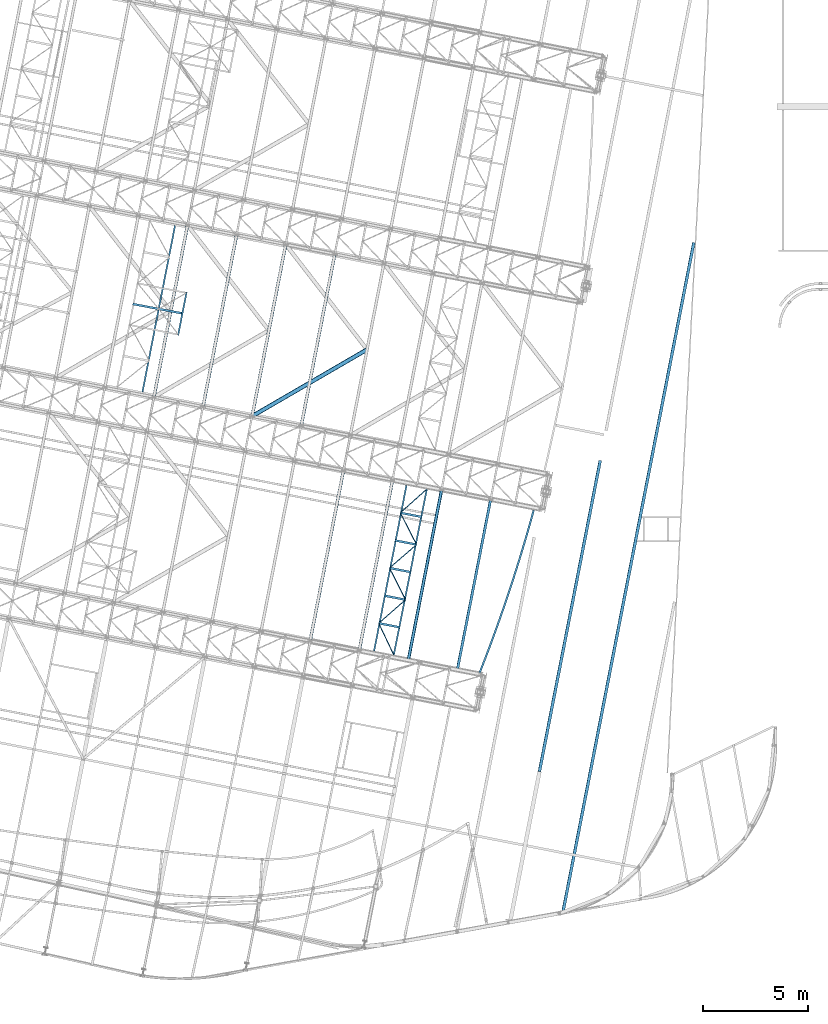
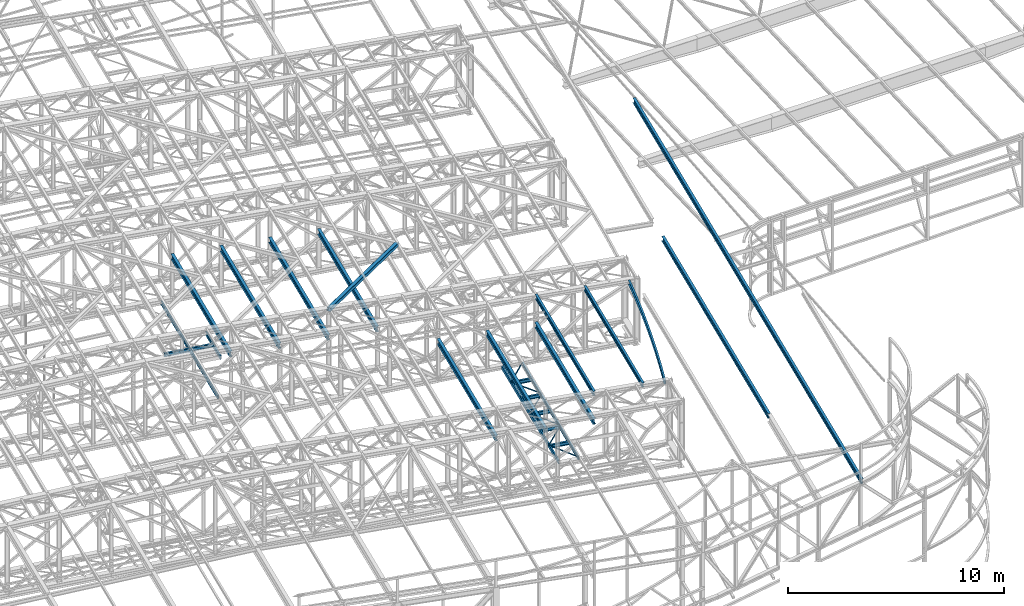
# One storey, part 61 of 215: 29 beams, 29 elements without a shape of their own.
"""IFC2X3 building model written with IfcOpenShell, lengths in millimetres."""

from ifc_helpers import new_model, entity, si_unit, frame, origin_with_axes, origin_2d_with_axis, place, context, subcontext, project, spatial, hollow_rectangle, i_section, u_section, extrude, clip, halfspace, material, type_object, element, aggregate, save


model = new_model("IFC2X3")

# Units and contexts
model_context = context("Model", 3, precision=1e-05, world=origin_with_axes())
body_context = subcontext(model_context, "Body", "Model", "MODEL_VIEW")
ifc_project = project(units=[si_unit("LENGTHUNIT", "METRE", prefix="MILLI"), si_unit("AREAUNIT", "SQUARE_METRE"), si_unit("VOLUMEUNIT", "CUBIC_METRE"), si_unit("MASSUNIT", "GRAM", prefix="KILO"), si_unit("TIMEUNIT", "SECOND"), si_unit("PLANEANGLEUNIT", "RADIAN"), si_unit("SOLIDANGLEUNIT", "STERADIAN"), si_unit("THERMODYNAMICTEMPERATUREUNIT", "DEGREE_CELSIUS"), si_unit("LUMINOUSINTENSITYUNIT", "LUMEN")], contexts=[model_context])

# Site, building, storey
site_placement = place(None, origin_with_axes())
site = spatial("IfcSite", under=ifc_project, at=site_placement, CompositionType="ELEMENT")
building_placement = place(site_placement, origin_with_axes())
building = spatial("IfcBuilding", under=site, at=building_placement, Name="Undefined", CompositionType="ELEMENT")
storey_placement = place(building_placement, origin_with_axes())
storey = spatial("IfcBuildingStorey", under=building, at=storey_placement, Name="Undefined", CompositionType="ELEMENT", Elevation=0.0)

# Assembly, beam
assembly_1_placement = place(storey_placement, origin_with_axes())
assembly_1 = element("IfcElementAssembly", 1, at=assembly_1_placement, inside=storey, Name="Steel Assembly", AssemblyPlace="NOTDEFINED", PredefinedType="RIGID_FRAME")
ifc_material = material(Name="STEEL/S275JR")
beam_type_1 = type_object("IfcBeamType", Name="IPE240", PredefinedType="NOTDEFINED")
beam_1_placement = place(assembly_1_placement, frame((88615.8050227052, 14980.3122329847, 12133.5283917348), z_axis=(0.0304080349965938, -0.00594450399933318, 0.999519891888024), x_axis=(0.191859470081235, 0.981422408415534, 0.0)))
beam_1 = element("IfcBeam", 2, at=beam_1_placement, type_object=beam_type_1, material=ifc_material, ObjectType="IPE240", context=body_context, shape_type="SweptSolid", body=[
    extrude(i_section(OverallWidth=120.0, OverallDepth=240.0, WebThickness=6.199999809, FlangeThickness=9.800000191, FilletRadius=15.0, at=origin_2d_with_axis()), frame((8299.99563379892, -2.30371156423296e-13, -3.63797880709171e-12), z_axis=(-1.0, 0.0, 0.0), x_axis=(-6.93889390390723e-18, -1.0, -3.46944695195361e-18)), (0.0, 0.0, 1.0), 8300.0),
])
aggregate(assembly_1, [beam_1])

assembly_2_placement = place(storey_placement, origin_with_axes())
assembly_2 = element("IfcElementAssembly", 3, at=assembly_2_placement, inside=storey, Name="Steel Assembly", AssemblyPlace="NOTDEFINED", PredefinedType="RIGID_FRAME")
beam_2_placement = place(assembly_2_placement, frame((86271.7572137781, 15438.5533442325, 12207.5658611621), z_axis=(0.0304080349965938, -0.00594450399933318, 0.999519891888024), x_axis=(0.191859470081235, 0.981422408415534, 0.0)))
beam_2 = element("IfcBeam", 4, at=beam_2_placement, type_object=beam_type_1, material=ifc_material, ObjectType="IPE240", context=body_context, shape_type="SweptSolid", body=[
    extrude(i_section(OverallWidth=120.0, OverallDepth=240.0, WebThickness=6.199999809, FlangeThickness=9.800000191, FilletRadius=15.0, at=origin_2d_with_axis()), frame((8299.99526300685, 1.47838788079098e-11, -1.71639879146031e-21), z_axis=(-1.0, 0.0, 0.0), x_axis=(-6.93889390390723e-18, -1.0, -3.46944695195361e-18)), (0.0, 0.0, 1.0), 8300.0),
])
aggregate(assembly_2, [beam_2])

assembly_3_placement = place(storey_placement, origin_with_axes())
assembly_3 = element("IfcElementAssembly", 5, at=assembly_3_placement, inside=storey, Name="Steel Assembly", AssemblyPlace="NOTDEFINED", PredefinedType="RIGID_FRAME")
beam_type_2 = type_object("IfcBeamType", Name="IPE270", PredefinedType="NOTDEFINED")
beam_3_placement = place(assembly_3_placement, frame((93695.5619479493, 3604.29824031149, 11896.3243337661), z_axis=(0.0304080349965938, -0.00594450399933318, 0.999519891888024), x_axis=(0.191859470081235, 0.981422408415534, 0.0)))
beam_3 = element("IfcBeam", 6, at=beam_3_placement, type_object=beam_type_2, material=ifc_material, ObjectType="IPE270", context=body_context, shape_type="Clipping", body=[
    clip(extrude(i_section(OverallWidth=135.0, OverallDepth=270.0, WebThickness=6.599999905, FlangeThickness=10.19999981, FilletRadius=15.0, at=origin_2d_with_axis()), frame((32375.5833869909, -1.36533122755691e-11, 1.81898940354586e-12), z_axis=(-1.0, 0.0, 0.0), x_axis=(-6.93889390390723e-18, -1.0, -3.46944695195361e-18)), (0.0, 0.0, 1.0), 32542.0), halfspace(frame((-223.820394315899, -78.4081149981939, -11899.6080636014), z_axis=(-0.932135446548258, -0.361935950950083, 0.0112194785145836), x_axis=(2.6746783987619e-10, -0.0309836363287614, -0.999519891888024)), False)),
])
aggregate(assembly_3, [beam_3])

assembly_4_placement = place(storey_placement, origin_with_axes())
assembly_4 = element("IfcElementAssembly", 7, at=assembly_4_placement, inside=storey, Name="Steel Assembly", AssemblyPlace="NOTDEFINED", PredefinedType="RIGID_FRAME")
beam_4_placement = place(assembly_4_placement, frame((92536.2646063667, 10122.9161485782, 11968.2693713485), z_axis=(0.0303815210100789, -0.0060801320020156, 0.999519882331488), x_axis=(0.191859463974626, 0.981422399870203, 0.000138261999981662)))
beam_4 = element("IfcBeam", 8, at=beam_4_placement, type_object=beam_type_2, material=ifc_material, ObjectType="IPE270", context=body_context, shape_type="SweptSolid", body=[
    extrude(i_section(OverallWidth=135.0, OverallDepth=270.0, WebThickness=6.599999905, FlangeThickness=10.19999981, FilletRadius=15.0, at=origin_2d_with_axis()), frame((15133.6773320891, -1.24995371028915e-13, 1.81857920439983e-12), z_axis=(-1.0, 0.0, 0.0), x_axis=(-6.93889390390723e-18, -1.0, -3.46944695195361e-18)), (0.0, 0.0, 1.0), 15133.7),
])
aggregate(assembly_4, [beam_4])

assembly_5_placement = place(storey_placement, origin_with_axes())
assembly_5 = element("IfcElementAssembly", 9, at=assembly_5_placement, inside=storey, Name="Steel Assembly", AssemblyPlace="NOTDEFINED", PredefinedType="RIGID_FRAME")
beam_type_3 = type_object("IfcBeamType", PredefinedType="NOTDEFINED")
beam_5_placement = place(assembly_5_placement, frame((84862.7233341026, 17205.039735155, 8705.0), z_axis=(0.0, 0.0, -1.0), x_axis=(0.429200813011826, -0.903209091024879, 0.0)))
beam_5 = element("IfcBeam", 10, at=beam_5_placement, type_object=beam_type_3, material=ifc_material, context=body_context, shape_type="SweptSolid", body=[
    extrude(hollow_rectangle(XDim=50.0, YDim=50.0, WallThickness=3.0, InnerFilletRadius=3.0, OuterFilletRadius=6.0, at=origin_2d_with_axis()), frame((1670.47101214338, 0.0, 0.0), z_axis=(-1.0, 0.0, 0.0), x_axis=(-6.93889390390723e-18, -1.0, -3.46944695195361e-18)), (0.0, 0.0, 1.0), 1670.5),
])
aggregate(assembly_5, [beam_5])

assembly_6_placement = place(storey_placement, origin_with_axes())
assembly_6 = element("IfcElementAssembly", 11, at=assembly_6_placement, inside=storey, Name="Steel Assembly", AssemblyPlace="NOTDEFINED", PredefinedType="RIGID_FRAME")
beam_6_placement = place(assembly_6_placement, frame((86144.5485289016, 18323.2135698641, 8705.0), z_axis=(0.0, 0.0, -1.0), x_axis=(-0.753573164058399, -0.657364044050946, 0.0)))
beam_6 = element("IfcBeam", 12, at=beam_6_placement, type_object=beam_type_3, material=ifc_material, context=body_context, shape_type="SweptSolid", body=[
    extrude(hollow_rectangle(XDim=50.0, YDim=50.0, WallThickness=3.0, InnerFilletRadius=3.0, OuterFilletRadius=6.0, at=origin_2d_with_axis()), frame((1700.99634170737, 3.77697060673333e-13, 0.0), z_axis=(-1.0, 0.0, 0.0), x_axis=(-6.93889390390723e-18, -1.0, -3.46944695195361e-18)), (0.0, 0.0, 1.0), 1701.0),
])
aggregate(assembly_6, [beam_6])

assembly_7_placement = place(storey_placement, origin_with_axes())
assembly_7 = element("IfcElementAssembly", 13, at=assembly_7_placement, inside=storey, Name="Steel Assembly", AssemblyPlace="NOTDEFINED", PredefinedType="RIGID_FRAME")
beam_7_placement = place(assembly_7_placement, frame((85378.1889632659, 19841.7923695502, 8705.0), z_axis=(0.0, 0.0, -1.0), x_axis=(0.450535692998692, -0.892758415997401, 0.0)))
beam_7 = element("IfcBeam", 14, at=beam_7_placement, type_object=beam_type_3, material=ifc_material, context=body_context, shape_type="SweptSolid", body=[
    extrude(hollow_rectangle(XDim=50.0, YDim=50.0, WallThickness=3.0, InnerFilletRadius=3.0, OuterFilletRadius=6.0, at=origin_2d_with_axis()), frame((1700.99634170737, 3.77697060673333e-13, 0.0), z_axis=(-1.0, 0.0, 0.0), x_axis=(-6.93889390390723e-18, -1.0, -3.46944695195361e-18)), (0.0, 0.0, 1.0), 1701.0),
])
aggregate(assembly_7, [beam_7])

assembly_8_placement = place(storey_placement, origin_with_axes())
assembly_8 = element("IfcElementAssembly", 15, at=assembly_8_placement, inside=storey, Name="Steel Assembly", AssemblyPlace="NOTDEFINED", PredefinedType="RIGID_FRAME")
beam_8_placement = place(assembly_8_placement, frame((86669.9593451968, 20958.016573475, 8705.0), z_axis=(0.0, 0.0, -1.0), x_axis=(-0.756647874878776, -0.653822600895252, 0.0)))
beam_8 = element("IfcBeam", 16, at=beam_8_placement, type_object=beam_type_3, material=ifc_material, context=body_context, shape_type="SweptSolid", body=[
    extrude(hollow_rectangle(XDim=50.0, YDim=50.0, WallThickness=3.0, InnerFilletRadius=3.0, OuterFilletRadius=6.0, at=origin_2d_with_axis()), frame((1707.22792651481, -9.47701876149905e-14, 1.81898940354586e-12), z_axis=(-1.0, 0.0, 0.0), x_axis=(-6.93889390390723e-18, -1.0, -3.46944695195361e-18)), (0.0, 0.0, 1.0), 1707.2),
])
aggregate(assembly_8, [beam_8])

assembly_9_placement = place(storey_placement, origin_with_axes())
assembly_9 = element("IfcElementAssembly", 17, at=assembly_9_placement, inside=storey, Name="Steel Assembly", AssemblyPlace="NOTDEFINED", PredefinedType="RIGID_FRAME")
beam_9_placement = place(assembly_9_placement, frame((85893.6545924291, 22478.5450039453, 8705.0), z_axis=(0.0, 0.0, -1.0), x_axis=(0.454714296839655, -0.89063736068594, 0.0)))
beam_9 = element("IfcBeam", 18, at=beam_9_placement, type_object=beam_type_3, material=ifc_material, context=body_context, shape_type="SweptSolid", body=[
    extrude(hollow_rectangle(XDim=50.0, YDim=50.0, WallThickness=3.0, InnerFilletRadius=3.0, OuterFilletRadius=6.0, at=origin_2d_with_axis()), frame((1707.23629790502, -9.47706523204982e-14, 1.81898940354586e-12), z_axis=(-1.0, 0.0, 0.0), x_axis=(-6.93889390390723e-18, -1.0, -3.46944695195361e-18)), (0.0, 0.0, 1.0), 1707.2),
])
aggregate(assembly_9, [beam_9])

assembly_10_placement = place(storey_placement, origin_with_axes())
assembly_10 = element("IfcElementAssembly", 19, at=assembly_10_placement, inside=storey, Name="Steel Assembly", AssemblyPlace="NOTDEFINED", PredefinedType="RIGID_FRAME")
beam_10_placement = place(assembly_10_placement, frame((87153.5801525349, 23601.1493481174, 8705.0), z_axis=(0.0, 0.0, -1.0), x_axis=(-0.746622988916558, -0.665247406925653, 0.0)))
beam_10 = element("IfcBeam", 20, at=beam_10_placement, type_object=beam_type_3, material=ifc_material, context=body_context, shape_type="SweptSolid", body=[
    extrude(hollow_rectangle(XDim=50.0, YDim=50.0, WallThickness=3.0, InnerFilletRadius=3.0, OuterFilletRadius=6.0, at=origin_2d_with_axis()), frame((1687.49901639851, 0.0, 0.0), z_axis=(-1.0, 0.0, 0.0), x_axis=(-6.93889390390723e-18, -1.0, -3.46944695195361e-18)), (0.0, 0.0, 1.0), 1687.5),
])
aggregate(assembly_10, [beam_10])

assembly_11_placement = place(storey_placement, origin_with_axes())
assembly_11 = element("IfcElementAssembly", 21, at=assembly_11_placement, inside=storey, Name="Steel Assembly", AssemblyPlace="NOTDEFINED", PredefinedType="RIGID_FRAME")
beam_type_4 = type_object("IfcBeamType", Name="UPN200", PredefinedType="NOTDEFINED")
beam_11_placement = place(assembly_11_placement, frame((86188.1907378032, 23789.726542302, 8630.00000003358), z_axis=(0.0, 0.0, -1.0), x_axis=(-0.191860814904866, -0.981422145513357, 0.0)))
beam_11 = element("IfcBeam", 22, at=beam_11_placement, type_object=beam_type_4, material=ifc_material, ObjectType="UPN200", context=body_context, shape_type="SweptSolid", body=[
    extrude(u_section(Depth=200.0, FlangeWidth=75.0, WebThickness=8.5, FlangeThickness=11.5, FilletRadius=11.5, EdgeRadius=6.0, FlangeSlope=0.0798299857122373, at=origin_2d_with_axis()), frame((8059.99524990843, 1.47756250359873e-11, 0.0), z_axis=(-1.0, 0.0, 0.0), x_axis=(-6.93889390390723e-18, -1.0, -3.46944695195361e-18)), (0.0, 0.0, 1.0), 8060.0),
])
aggregate(assembly_11, [beam_11])

assembly_12_placement = place(storey_placement, origin_with_axes())
assembly_12 = element("IfcElementAssembly", 23, at=assembly_12_placement, inside=storey, Name="Steel Assembly", AssemblyPlace="NOTDEFINED", PredefinedType="RIGID_FRAME")
beam_12_placement = place(assembly_12_placement, frame((85583.8611288967, 15695.4357512324, 8630.00000000009), z_axis=(0.0, 0.0, -1.0), x_axis=(0.195270302960115, 0.980749462799682, 0.0)))
beam_12 = element("IfcBeam", 24, at=beam_12_placement, type_object=beam_type_4, material=ifc_material, ObjectType="UPN200", context=body_context, shape_type="SweptSolid", body=[
    extrude(u_section(Depth=200.0, FlangeWidth=75.0, WebThickness=8.5, FlangeThickness=11.5, FilletRadius=11.5, EdgeRadius=6.0, FlangeSlope=0.0798299857122373, at=origin_2d_with_axis()), frame((8060.04387248816, 0.0, 1.81898940354586e-12), z_axis=(-1.0, 0.0, 0.0), x_axis=(-6.93889390390723e-18, -1.0, -3.46944695195361e-18)), (0.0, 0.0, 1.0), 8060.0),
])
aggregate(assembly_12, [beam_12])

assembly_13_placement = place(storey_placement, origin_with_axes())
assembly_13 = element("IfcElementAssembly", 25, at=assembly_13_placement, inside=storey, Name="Steel Assembly", AssemblyPlace="NOTDEFINED", PredefinedType="RIGID_FRAME")
beam_13_placement = place(assembly_13_placement, frame((75284.6586090742, 30951.0659829193, 8670.00000003361), z_axis=(0.0, 0.0, -1.0), x_axis=(0.191927031081811, 0.981409198418337, 0.0)))
beam_13 = element("IfcBeam", 26, at=beam_13_placement, type_object=beam_type_4, material=ifc_material, ObjectType="UPN200", context=body_context, shape_type="SweptSolid", body=[
    extrude(u_section(Depth=200.0, FlangeWidth=75.0, WebThickness=8.5, FlangeThickness=11.5, FilletRadius=11.5, EdgeRadius=6.0, FlangeSlope=0.0798299857122373, at=origin_2d_with_axis()), frame((2102.26217859175, 0.0, 0.0), z_axis=(-1.0, 0.0, 0.0), x_axis=(-6.93889390390723e-18, -1.0, -3.46944695195361e-18)), (0.0, 0.0, 1.0), 2102.3),
])
aggregate(assembly_13, [beam_13])

assembly_14_placement = place(storey_placement, origin_with_axes())
assembly_14 = element("IfcElementAssembly", 27, at=assembly_14_placement, inside=storey, Name="Steel Assembly", AssemblyPlace="NOTDEFINED", PredefinedType="RIGID_FRAME")
beam_14_placement = place(assembly_14_placement, frame((73583.9430896979, 28250.8576961141, 8670.00000000005), z_axis=(0.0, 0.0, -1.0), x_axis=(0.192120705997516, 0.981371302987313, 0.0)))
beam_14 = element("IfcBeam", 28, at=beam_14_placement, type_object=beam_type_4, material=ifc_material, ObjectType="UPN200", context=body_context, shape_type="SweptSolid", body=[
    extrude(u_section(Depth=200.0, FlangeWidth=75.0, WebThickness=8.5, FlangeThickness=11.5, FilletRadius=11.5, EdgeRadius=6.0, FlangeSlope=0.0798299857122373, at=origin_2d_with_axis()), frame((8081.40136371167, 0.0, 0.0), z_axis=(-1.0, 0.0, 0.0), x_axis=(-6.93889390390723e-18, -1.0, -3.46944695195361e-18)), (0.0, 0.0, 1.0), 8081.4),
])
aggregate(assembly_14, [beam_14])

assembly_15_placement = place(storey_placement, origin_with_axes())
assembly_15 = element("IfcElementAssembly", 29, at=assembly_15_placement, inside=storey, Name="Steel Assembly", AssemblyPlace="NOTDEFINED", PredefinedType="RIGID_FRAME")
beam_type_5 = type_object("IfcBeamType", PredefinedType="NOTDEFINED")
beam_15_placement = place(assembly_15_placement, frame((84303.9532591256, 30272.6186531078, 12340.6479480826), z_axis=(0.0304080349965938, -0.00594450399933318, 0.999519891888024), x_axis=(-0.864628555736928, -0.501870164847301, 0.0233194819929049)))
beam_15 = element("IfcBeam", 30, at=beam_15_placement, type_object=beam_type_5, material=ifc_material, context=body_context, shape_type="SweptSolid", body=[
    extrude(hollow_rectangle(XDim=200.0, YDim=200.0, WallThickness=10.0, InnerFilletRadius=15.0, OuterFilletRadius=25.0, at=origin_2d_with_axis()), frame((6349.83661532856, 5.61049270900543e-12, 1.81898940354586e-12), z_axis=(-1.0, 0.0, 0.0), x_axis=(-6.93889390390723e-18, -1.0, -3.46944695195361e-18)), (0.0, 0.0, 1.0), 6349.8),
])
aggregate(assembly_15, [beam_15])

assembly_16_placement = place(storey_placement, origin_with_axes())
assembly_16 = element("IfcElementAssembly", 31, at=assembly_16_placement, inside=storey, Name="Steel Assembly", AssemblyPlace="NOTDEFINED", PredefinedType="RIGID_FRAME")
beam_type_6 = type_object("IfcBeamType", Name="IPE300", PredefinedType="NOTDEFINED")
beam_16_placement = place(assembly_16_placement, frame((81161.8605922281, 26626.7811873851, 10827.66000008), z_axis=(0.0, 0.0, 1.0), x_axis=(0.191859470081235, 0.981422408415534, 0.0)))
beam_16 = element("IfcBeam", 32, at=beam_16_placement, type_object=beam_type_6, material=ifc_material, Name="SUPPORT", ObjectType="IPE300", context=body_context, shape_type="SweptSolid", body=[
    extrude(i_section(OverallWidth=150.0, OverallDepth=300.0, WebThickness=7.099999905, FlangeThickness=10.69999981, FilletRadius=15.0, at=origin_2d_with_axis()), frame((8361.40106173832, 0.0, -1.81898940354586e-12), z_axis=(-1.0, 0.0, 0.0), x_axis=(-6.93889390390723e-18, -1.0, -3.46944695195361e-18)), (0.0, 0.0, 1.0), 8361.4),
])
aggregate(assembly_16, [beam_16])

assembly_17_placement = place(storey_placement, origin_with_axes())
assembly_17 = element("IfcElementAssembly", 33, at=assembly_17_placement, inside=storey, Name="Steel Assembly", AssemblyPlace="NOTDEFINED", PredefinedType="RIGID_FRAME")
beam_17_placement = place(assembly_17_placement, frame((78817.8127133791, 27085.0219340605, 10901.7000000974), z_axis=(0.0, 0.0, 1.0), x_axis=(0.191859470081235, 0.981422408415534, 0.0)))
beam_17 = element("IfcBeam", 34, at=beam_17_placement, type_object=beam_type_6, material=ifc_material, Name="SUPPORT", ObjectType="IPE300", context=body_context, shape_type="SweptSolid", body=[
    extrude(i_section(OverallWidth=150.0, OverallDepth=300.0, WebThickness=7.099999905, FlangeThickness=10.69999981, FilletRadius=15.0, at=origin_2d_with_axis()), frame((8361.40106173832, 0.0, -1.81898940354586e-12), z_axis=(-1.0, 0.0, 0.0), x_axis=(-6.93889390390723e-18, -1.0, -3.46944695195361e-18)), (0.0, 0.0, 1.0), 8361.4),
])
aggregate(assembly_17, [beam_17])

assembly_18_placement = place(storey_placement, origin_with_axes())
assembly_18 = element("IfcElementAssembly", 35, at=assembly_18_placement, inside=storey, Name="Steel Assembly", AssemblyPlace="NOTDEFINED", PredefinedType="RIGID_FRAME")
beam_18_placement = place(assembly_18_placement, frame((76473.7648323749, 27543.2626810585, 10975.7300001147), z_axis=(0.0, 0.0, 1.0), x_axis=(0.191859470081235, 0.981422408415534, 0.0)))
beam_18 = element("IfcBeam", 36, at=beam_18_placement, type_object=beam_type_6, material=ifc_material, Name="SUPPORT", ObjectType="IPE300", context=body_context, shape_type="SweptSolid", body=[
    extrude(i_section(OverallWidth=150.0, OverallDepth=300.0, WebThickness=7.099999905, FlangeThickness=10.69999981, FilletRadius=15.0, at=origin_2d_with_axis()), frame((8361.40106173832, 0.0, -1.81898940354586e-12), z_axis=(-1.0, 0.0, 0.0), x_axis=(-6.93889390390723e-18, -1.0, -3.46944695195361e-18)), (0.0, 0.0, 1.0), 8361.4),
])
aggregate(assembly_18, [beam_18])

assembly_19_placement = place(storey_placement, origin_with_axes())
assembly_19 = element("IfcElementAssembly", 37, at=assembly_19_placement, inside=storey, Name="Steel Assembly", AssemblyPlace="NOTDEFINED", PredefinedType="RIGID_FRAME")
beam_19_placement = place(assembly_19_placement, frame((74129.7169528187, 28001.5034277734, 11049.7700001321), z_axis=(0.0, 0.0, 1.0), x_axis=(0.191859470081235, 0.981422408415534, 0.0)))
beam_19 = element("IfcBeam", 38, at=beam_19_placement, type_object=beam_type_6, material=ifc_material, Name="SUPPORT", ObjectType="IPE300", context=body_context, shape_type="SweptSolid", body=[
    extrude(i_section(OverallWidth=150.0, OverallDepth=300.0, WebThickness=7.099999905, FlangeThickness=10.69999981, FilletRadius=15.0, at=origin_2d_with_axis()), frame((8361.40106173832, 0.0, -1.81898940354586e-12), z_axis=(-1.0, 0.0, 0.0), x_axis=(-6.93889390390723e-18, -1.0, -3.46944695195361e-18)), (0.0, 0.0, 1.0), 8361.4),
])
aggregate(assembly_19, [beam_19])

assembly_20_placement = place(storey_placement, origin_with_axes())
assembly_20 = element("IfcElementAssembly", 39, at=assembly_20_placement, inside=storey, Name="Steel Assembly", AssemblyPlace="NOTDEFINED", PredefinedType="RIGID_FRAME")
beam_20_placement = place(assembly_20_placement, frame((86275.4106278884, 15437.8394588333, 10605.5499977022), z_axis=(0.0, 0.0, 1.0), x_axis=(0.191859470081235, 0.981422408415534, 0.0)))
beam_20 = element("IfcBeam", 40, at=beam_20_placement, type_object=beam_type_6, material=ifc_material, Name="SUPPORT", ObjectType="IPE300", context=body_context, shape_type="SweptSolid", body=[
    extrude(i_section(OverallWidth=150.0, OverallDepth=300.0, WebThickness=7.099999905, FlangeThickness=10.69999981, FilletRadius=15.0, at=origin_2d_with_axis()), frame((8299.99526300685, 1.47838788079098e-11, -1.71639879146031e-21), z_axis=(-1.0, 0.0, 0.0), x_axis=(-6.93889390390723e-18, -1.0, -3.46944695195361e-18)), (0.0, 0.0, 1.0), 8300.0),
])
aggregate(assembly_20, [beam_20])

assembly_21_placement = place(storey_placement, origin_with_axes())
assembly_21 = element("IfcElementAssembly", 41, at=assembly_21_placement, inside=storey, Name="Steel Assembly", AssemblyPlace="NOTDEFINED", PredefinedType="RIGID_FRAME")
beam_21_placement = place(assembly_21_placement, frame((83931.3627476414, 15896.0802058806, 10679.5800000712), z_axis=(0.0, 0.0, 1.0), x_axis=(0.191859470081235, 0.981422408415534, 0.0)))
beam_21 = element("IfcBeam", 42, at=beam_21_placement, type_object=beam_type_6, material=ifc_material, Name="SUPPORT", ObjectType="IPE300", context=body_context, shape_type="SweptSolid", body=[
    extrude(i_section(OverallWidth=150.0, OverallDepth=300.0, WebThickness=7.099999905, FlangeThickness=10.69999981, FilletRadius=15.0, at=origin_2d_with_axis()), frame((8299.99526300685, 1.47838788079098e-11, -1.71639879146031e-21), z_axis=(-1.0, 0.0, 0.0), x_axis=(-6.93889390390723e-18, -1.0, -3.46944695195361e-18)), (0.0, 0.0, 1.0), 8300.0),
])
aggregate(assembly_21, [beam_21])

assembly_22_placement = place(storey_placement, origin_with_axes())
assembly_22 = element("IfcElementAssembly", 43, at=assembly_22_placement, inside=storey, Name="Steel Assembly", AssemblyPlace="NOTDEFINED", PredefinedType="RIGID_FRAME")
beam_22_placement = place(assembly_22_placement, frame((81587.3148670331, 16354.3209528012, 10753.6200000398), z_axis=(0.0, 0.0, 1.0), x_axis=(0.191859470081235, 0.981422408415534, 0.0)))
beam_22 = element("IfcBeam", 44, at=beam_22_placement, type_object=beam_type_6, material=ifc_material, Name="SUPPORT", ObjectType="IPE300", context=body_context, shape_type="SweptSolid", body=[
    extrude(i_section(OverallWidth=150.0, OverallDepth=300.0, WebThickness=7.099999905, FlangeThickness=10.69999981, FilletRadius=15.0, at=origin_2d_with_axis()), frame((8299.99526300685, 1.47838788079098e-11, -1.71639879146031e-21), z_axis=(-1.0, 0.0, 0.0), x_axis=(-6.93889390390723e-18, -1.0, -3.46944695195361e-18)), (0.0, 0.0, 1.0), 8300.0),
])
aggregate(assembly_22, [beam_22])

assembly_23_placement = place(storey_placement, origin_with_axes())
assembly_23 = element("IfcElementAssembly", 45, at=assembly_23_placement, inside=storey, Name="Steel Assembly", AssemblyPlace="NOTDEFINED", PredefinedType="RIGID_FRAME")
beam_type_7 = type_object("IfcBeamType", Name="IPE200", PredefinedType="NOTDEFINED")
beam_23_placement = place(assembly_23_placement, frame((85882.5937401251, 17005.6626173808, 8630.00000000005), z_axis=(0.0, 0.0, -1.0), x_axis=(-0.981422136295317, 0.191860862057732, 0.0)))
beam_23 = element("IfcBeam", 46, at=beam_23_placement, type_object=beam_type_7, material=ifc_material, ObjectType="IPE200", context=body_context, shape_type="SweptSolid", body=[
    extrude(i_section(OverallWidth=100.0, OverallDepth=200.0, WebThickness=5.599999905, FlangeThickness=8.5, FilletRadius=12.0, at=origin_2d_with_axis()), frame((1039.17605831378, -7.27595761418343e-12, -1.81898940354586e-12), z_axis=(-1.0, 0.0, 0.0), x_axis=(-6.93889390390723e-18, -1.0, -3.46944695195361e-18)), (0.0, 0.0, 1.0), 1039.2),
])
aggregate(assembly_23, [beam_23])

assembly_24_placement = place(storey_placement, origin_with_axes())
assembly_24 = element("IfcElementAssembly", 47, at=assembly_24_placement, inside=storey, Name="Steel Assembly", AssemblyPlace="NOTDEFINED", PredefinedType="RIGID_FRAME")
beam_24_placement = place(assembly_24_placement, frame((86144.5485289016, 18323.2135698641, 8630.00000000005), z_axis=(0.0, 0.0, -1.0), x_axis=(-0.981422136295317, 0.191860862057732, 0.0)))
beam_24 = element("IfcBeam", 48, at=beam_24_placement, type_object=beam_type_7, material=ifc_material, ObjectType="IPE200", context=body_context, shape_type="SweptSolid", body=[
    extrude(i_section(OverallWidth=100.0, OverallDepth=200.0, WebThickness=5.599999905, FlangeThickness=8.5, FilletRadius=12.0, at=origin_2d_with_axis()), frame((1043.47795243299, 0.0, 1.81898940354586e-12), z_axis=(-1.0, 0.0, 0.0), x_axis=(-6.93889390390723e-18, -1.0, -3.46944695195361e-18)), (0.0, 0.0, 1.0), 1043.5),
])
aggregate(assembly_24, [beam_24])

assembly_25_placement = place(storey_placement, origin_with_axes())
assembly_25 = element("IfcElementAssembly", 49, at=assembly_25_placement, inside=storey, Name="Steel Assembly", AssemblyPlace="NOTDEFINED", PredefinedType="RIGID_FRAME")
beam_25_placement = place(assembly_25_placement, frame((86406.503317678, 19640.7645223474, 8630.00000000005), z_axis=(0.0, 0.0, -1.0), x_axis=(-0.981422136295317, 0.191860862057732, 0.0)))
beam_25 = element("IfcBeam", 50, at=beam_25_placement, type_object=beam_type_7, material=ifc_material, ObjectType="IPE200", context=body_context, shape_type="SweptSolid", body=[
    extrude(i_section(OverallWidth=100.0, OverallDepth=200.0, WebThickness=5.599999905, FlangeThickness=8.5, FilletRadius=12.0, at=origin_2d_with_axis()), frame((1047.77984655224, 2.90817327595128e-14, 1.81898940354586e-12), z_axis=(-1.0, 0.0, 0.0), x_axis=(-6.93889390390723e-18, -1.0, -3.46944695195361e-18)), (0.0, 0.0, 1.0), 1047.8),
])
aggregate(assembly_25, [beam_25])

assembly_26_placement = place(storey_placement, origin_with_axes())
assembly_26 = element("IfcElementAssembly", 51, at=assembly_26_placement, inside=storey, Name="Steel Assembly", AssemblyPlace="NOTDEFINED", PredefinedType="RIGID_FRAME")
beam_26_placement = place(assembly_26_placement, frame((86669.9593451968, 20958.016573475, 8630.00000000005), z_axis=(0.0, 0.0, -1.0), x_axis=(-0.981421185815644, 0.191865723963961, 0.0)))
beam_26 = element("IfcBeam", 52, at=beam_26_placement, type_object=beam_type_7, material=ifc_material, ObjectType="IPE200", context=body_context, shape_type="SweptSolid", body=[
    extrude(i_section(OverallWidth=100.0, OverallDepth=200.0, WebThickness=5.599999905, FlangeThickness=8.5, FilletRadius=12.0, at=origin_2d_with_axis()), frame((1053.61243710149, 7.30520123385096e-12, 0.0), z_axis=(-1.0, 0.0, 0.0), x_axis=(-6.93889390390723e-18, -1.0, -3.46944695195361e-18)), (0.0, 0.0, 1.0), 1053.6),
])
aggregate(assembly_26, [beam_26])

assembly_27_placement = place(storey_placement, origin_with_axes())
assembly_27 = element("IfcElementAssembly", 53, at=assembly_27_placement, inside=storey, Name="Steel Assembly", AssemblyPlace="NOTDEFINED", PredefinedType="RIGID_FRAME")
beam_27_placement = place(assembly_27_placement, frame((86930.4128952298, 22275.8664273142, 8630.00000000005), z_axis=(0.0, 0.0, -1.0), x_axis=(-0.981422136295317, 0.191860862057732, 0.0)))
beam_27 = element("IfcBeam", 54, at=beam_27_placement, type_object=beam_type_7, material=ifc_material, ObjectType="IPE200", context=body_context, shape_type="SweptSolid", body=[
    extrude(i_section(OverallWidth=100.0, OverallDepth=200.0, WebThickness=5.599999905, FlangeThickness=8.5, FilletRadius=12.0, at=origin_2d_with_axis()), frame((1056.38363478965, -2.93205358545171e-14, 0.0), z_axis=(-1.0, 0.0, 0.0), x_axis=(-6.93889390390723e-18, -1.0, -3.46944695195361e-18)), (0.0, 0.0, 1.0), 1056.4),
])
aggregate(assembly_27, [beam_27])

assembly_28_placement = place(storey_placement, origin_with_axes())
assembly_28 = element("IfcElementAssembly", 55, at=assembly_28_placement, inside=storey, Name="Steel Assembly", AssemblyPlace="NOTDEFINED", PredefinedType="RIGID_FRAME")
beam_28_placement = place(assembly_28_placement, frame((75517.6792493414, 31991.5061890373, 8670.00000000005), z_axis=(0.0, 0.0, -1.0), x_axis=(-0.982512751322469, 0.18619531006111, 0.0)))
beam_28 = element("IfcBeam", 56, at=beam_28_placement, type_object=beam_type_7, material=ifc_material, ObjectType="IPE200", context=body_context, shape_type="SweptSolid", body=[
    extrude(i_section(OverallWidth=100.0, OverallDepth=200.0, WebThickness=5.599999905, FlangeThickness=8.5, FilletRadius=12.0, at=origin_2d_with_axis()), frame((2441.99156798736, -6.77788816180013e-14, 0.0), z_axis=(-1.0, 0.0, 0.0), x_axis=(-6.93889390390723e-18, -1.0, -3.46944695195361e-18)), (0.0, 0.0, 1.0), 2442.0),
])
aggregate(assembly_28, [beam_28])

assembly_29_placement = place(storey_placement, origin_with_axes())
assembly_29 = element("IfcElementAssembly", 57, at=assembly_29_placement, inside=storey, Name="Steel Assembly", AssemblyPlace="NOTDEFINED", PredefinedType="RIGID_FRAME")
beam_type_8 = type_object("IfcBeamType", Name="UPE240", PredefinedType="NOTDEFINED")
beam_29_placement = place(assembly_29_placement, frame((89659.5788784387, 14784.1018702873, 12058.0268353284), z_axis=(-0.000346256000145019, 0.000115301000046656, -0.999999933406229), x_axis=(0.315940669837987, 0.948778948513469, -1.00000004666417e-09)))
beam_29 = element("IfcBeam", 58, at=beam_29_placement, type_object=beam_type_8, material=ifc_material, ObjectType="UPE240", context=body_context, shape_type="SweptSolid", body=[
    entity("IfcRevolvedAreaSolid", entity("IfcUShapeProfileDef", "AREA", None, entity("IfcAxis2Placement2D", entity("IfcCartesianPoint", [0.0, 0.0]), entity("IfcDirection", [1.0, 0.0])), 240.0, 90.0, 7.0, 12.5, 15.0), entity("IfcAxis2Placement3D", entity("IfcCartesianPoint", [8233.37866458423, 1.5139337061481e-13, -1.81917987595869e-12]), entity("IfcDirection", [-0.99849063994425, 0.0549221443838585, 2.60765913966752e-20]), entity("IfcDirection", [-0.0549221443838585, -0.99849063994425, -5.28577076190669e-20])), entity("IfcAxis1Placement", entity("IfcCartesianPoint", [74955.0, 0.0, 0.0]), entity("IfcDirection", [0.0, 1.0, 0.0])), 0.109899587015752),
])
aggregate(assembly_29, [beam_29])

save(model, "model.ifc")
